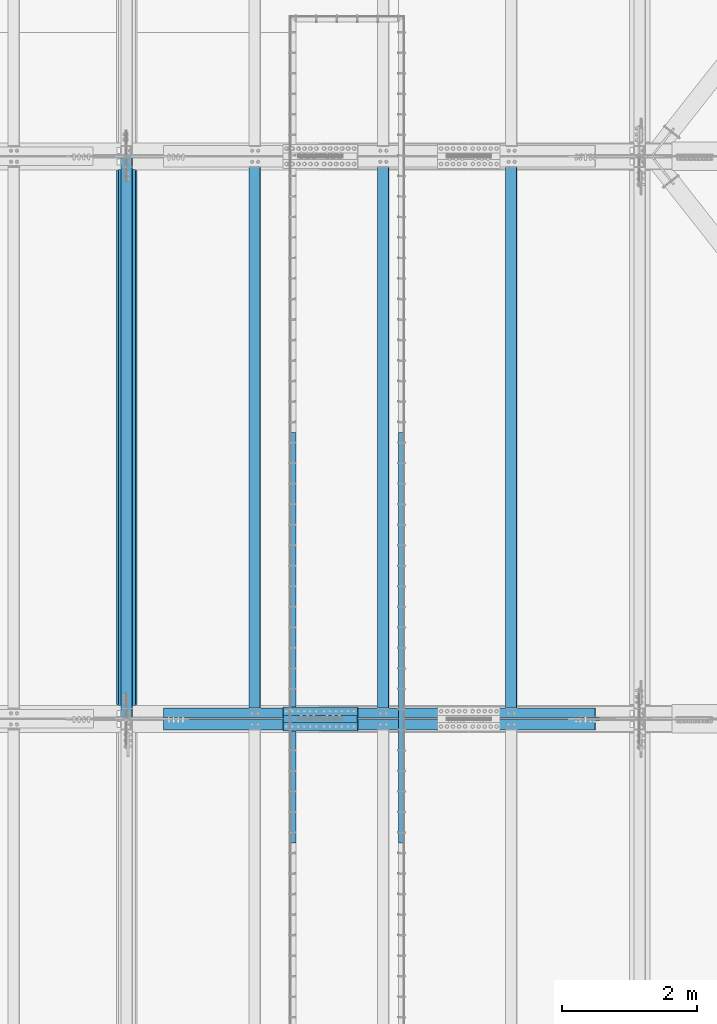
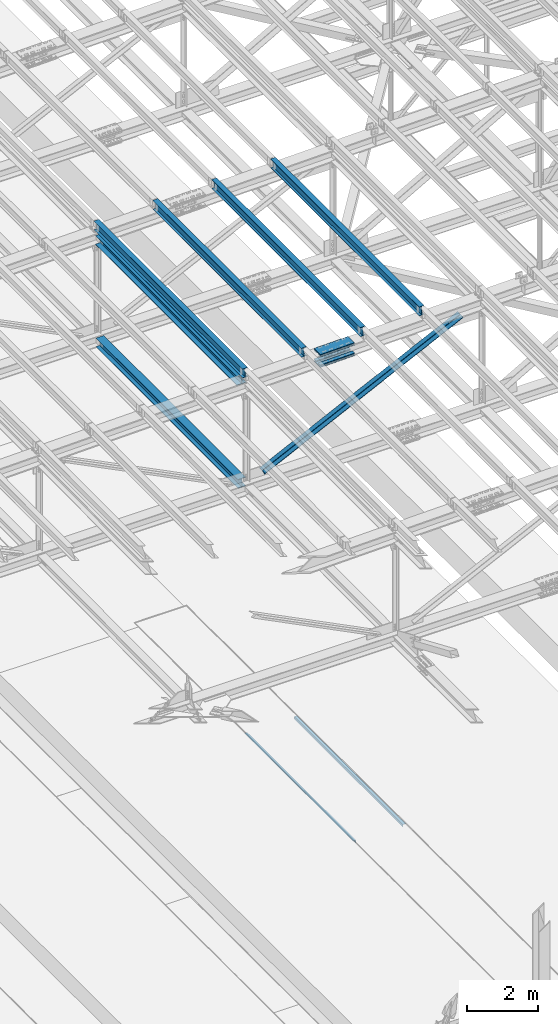
# One storey, part 1838 of 3843: 14 beams, 2 members, 11 elements without a shape of their own.
"""IFC2X3 building model written with IfcOpenShell, lengths in millimetres."""

from ifc_helpers import new_model, si_unit, frame, origin_with_axes, place, context, subcontext, project, spatial, faceted_brep, material, type_object, element, aggregate, save


model = new_model("IFC2X3")

# Units and contexts
model_context = context("Model", 3, precision=1e-05, world=origin_with_axes())
body_context = subcontext(model_context, "Body", "Model", "MODEL_VIEW")
ifc_project = project(units=[si_unit("LENGTHUNIT", "METRE", prefix="MILLI"), si_unit("AREAUNIT", "SQUARE_METRE"), si_unit("VOLUMEUNIT", "CUBIC_METRE"), si_unit("MASSUNIT", "GRAM", prefix="KILO"), si_unit("TIMEUNIT", "SECOND"), si_unit("PLANEANGLEUNIT", "RADIAN"), si_unit("SOLIDANGLEUNIT", "STERADIAN"), si_unit("THERMODYNAMICTEMPERATUREUNIT", "DEGREE_CELSIUS"), si_unit("LUMINOUSINTENSITYUNIT", "LUMEN")], contexts=[model_context])

# Site, building, storey
site_placement = place(None, origin_with_axes())
site = spatial("IfcSite", under=ifc_project, at=site_placement, CompositionType="ELEMENT")
building_placement = place(site_placement, origin_with_axes())
building = spatial("IfcBuilding", under=site, at=building_placement, Name="Undefined", CompositionType="ELEMENT")
storey_placement = place(building_placement, origin_with_axes())
storey = spatial("IfcBuildingStorey", under=building, at=storey_placement, Name="Undefined", CompositionType="ELEMENT", Elevation=0.0)

# Assembly, beam
assembly_1_placement = place(storey_placement, origin_with_axes())
assembly_1 = element("IfcElementAssembly", 1, at=assembly_1_placement, inside=storey, Name="EMBED_ANGLE", AssemblyPlace="NOTDEFINED", PredefinedType="RIGID_FRAME")
ifc_material_1 = material(Name="STEEL/A36")
beam_type_1 = type_object("IfcBeamType", Name="L3-1/2X3-1/2X5/16", PredefinedType="NOTDEFINED")
beam_1_placement = place(assembly_1_placement, frame((66713.862, 46456.6001953125, 30410.15), z_axis=(0.0, 0.0, -1.0), x_axis=(0.0, -1.0, 0.0)))
beam_1 = element("IfcBeam", 2, at=beam_1_placement, type_object=beam_type_1, material=ifc_material_1, Name="EMBED_ANGLE", ObjectType="L3-1/2X3-1/2X5/16", context=body_context, shape_type="Brep", body=[
    faceted_brep([(-3.63797880709171e-12, 44.4499999999971, -44.4500000000007), (-3.63797880709171e-12, 44.4499999999971, 44.4500000000007), (6096.0, 44.4499999999971, 44.4500000000007), (6096.0, 44.4499999999971, -44.4500000000007), (-3.63797880709171e-12, 36.5124999999971, 44.4500000000007), (6096.0, 36.5124999999971, 44.4500000000007), (-3.63797880709171e-12, 36.5124999999971, -36.5125000000007), (6096.0, 36.5124999999971, -36.5125000000007), (3.63797880709171e-12, -44.4499999999971, -36.5125000000007), (6096.0, -44.4499999999971, -36.5125000000007), (3.63797880709171e-12, -44.4499999999971, -44.4500000000007), (6096.0, -44.4499999999971, -44.4500000000007)], [[[0, 1, 2, 3]], [[1, 4, 5, 2]], [[4, 6, 7, 5]], [[6, 8, 9, 7]], [[8, 10, 11, 9]], [[10, 0, 3, 11]], [[5, 7, 9, 11, 3, 2]], [[10, 8, 6, 4, 1, 0]]]),
])
aggregate(assembly_1, [beam_1])

assembly_2_placement = place(storey_placement, origin_with_axes())
assembly_2 = element("IfcElementAssembly", 3, at=assembly_2_placement, inside=storey, Name="EMBED_ANGLE", AssemblyPlace="NOTDEFINED", PredefinedType="RIGID_FRAME")
beam_2_placement = place(assembly_2_placement, frame((65101.0255556641, 40360.6001953125, 30410.15), z_axis=(0.0, 0.0, -1.0), x_axis=(0.0, 1.0, 0.0)))
beam_2 = element("IfcBeam", 4, at=beam_2_placement, type_object=beam_type_1, material=ifc_material_1, Name="EMBED_ANGLE", ObjectType="L3-1/2X3-1/2X5/16", context=body_context, shape_type="Brep", body=[
    faceted_brep([(-3.63797880709171e-12, 44.4499999999971, -44.4500000000007), (-3.63797880709171e-12, 44.4499999999971, 44.4500000000007), (6096.0, 44.4499999999971, 44.4500000000007), (6096.0, 44.4499999999971, -44.4500000000007), (-3.63797880709171e-12, 36.5124999999971, 44.4500000000007), (6096.0, 36.5124999999971, 44.4500000000007), (-3.63797880709171e-12, 36.5124999999971, -36.5125000000007), (6096.0, 36.5124999999971, -36.5125000000007), (3.63797880709171e-12, -44.4499999999971, -36.5125000000007), (6096.0, -44.4499999999971, -36.5125000000007), (3.63797880709171e-12, -44.4499999999971, -44.4500000000007), (6096.0, -44.4499999999971, -44.4500000000007)], [[[0, 1, 2, 3]], [[1, 4, 5, 2]], [[4, 6, 7, 5]], [[6, 8, 9, 7]], [[8, 10, 11, 9]], [[10, 0, 3, 11]], [[5, 7, 9, 11, 3, 2]], [[10, 8, 6, 4, 1, 0]]]),
])
aggregate(assembly_2, [beam_2])

assembly_3_placement = place(storey_placement, origin_with_axes())
assembly_3 = element("IfcElementAssembly", 5, at=assembly_3_placement, inside=storey, Name="BEAM", AssemblyPlace="NOTDEFINED", PredefinedType="RIGID_FRAME")
ifc_material_2 = material(Name="STEEL/A992")
beam_type_2 = type_object("IfcBeamType", Name="W12X26", PredefinedType="NOTDEFINED")
beam_3_placement = place(assembly_3_placement, frame((62633.1092624511, 42201.8081954528, 46204.1114369362), z_axis=(-0.0211520982314614, -0.0018756519998351, 0.999774509912101), x_axis=(0.0, 0.999998240175376, 0.00187607200032924)))
beam_3 = element("IfcBeam", 6, at=beam_3_placement, type_object=beam_type_2, material=ifc_material_2, Name="BEAM", ObjectType="W12X26", context=body_context, shape_type="Brep", body=[
    faceted_brep([(12.6967464703193, 82.5499999994136, -155.575000000383), (12.7146120895923, 82.5499999994499, -146.050000000381), (8343.9292736213, 82.5499999999156, -146.050000022449), (8343.91140800202, 82.5499999998792, -155.575000022458), (12.7177619218128, 3.17499999958818, -146.050000000141), (8343.93242345352, 3.17500000005384, -146.050000022209), (13.2656409129268, 3.17500000040309, 146.050000000061), (8344.48030244464, 3.17500000086875, 146.049999977993), (13.2624910807062, 82.5500000002503, 146.049999999821), (8344.47715261242, 82.550000000716, 146.049999977753), (13.2803566999792, 82.5500000002867, 155.57499999983), (8344.49501823169, 82.5500000007523, 155.574999977762), (13.2869083509941, -82.5499999994208, 155.575000000332), (8344.50156988271, -82.5499999989552, 155.574999978257), (13.2690427317211, -82.5499999994499, 146.050000000323), (8344.48370426342, -82.549999998977, 146.049999978248), (13.2658928995006, -3.17499999958818, 146.050000000083), (8344.48055443121, -3.17499999912252, 146.049999978015), (12.7180139083866, -3.17500000041036, -146.050000000119), (8343.93267544009, -3.17499999993743, -146.050000022195), (12.7211637406144, -82.5500000002576, -146.049999999879), (8343.93582527231, -82.5499999997919, -146.050000021962), (12.7032981213342, -82.5500000002867, -155.574999999888), (8343.91795965304, -82.549999999821, -155.575000021956)], [[[0, 1, 2, 3]], [[1, 4, 5, 2]], [[4, 6, 7, 5]], [[6, 8, 9, 7]], [[8, 10, 11, 9]], [[10, 12, 13, 11]], [[12, 14, 15, 13]], [[14, 16, 17, 15]], [[16, 18, 19, 17]], [[18, 20, 21, 19]], [[20, 22, 23, 21]], [[22, 0, 3, 23]], [[5, 7, 9, 11, 13, 15, 17, 19, 21, 23, 3, 2]], [[22, 20, 18, 16, 14, 12, 10, 8, 6, 4, 1, 0]]]),
])
aggregate(assembly_3, [beam_3])

assembly_4_placement = place(storey_placement, origin_with_axes())
assembly_4 = element("IfcElementAssembly", 7, at=assembly_4_placement, inside=storey, Name="BEAM", AssemblyPlace="NOTDEFINED", PredefinedType="RIGID_FRAME")
beam_4_placement = place(assembly_4_placement, frame((68348.1092622879, 42201.7802351292, 46326.8579257853), z_axis=(-0.0211520977063192, -0.00205537399917375, 0.999774156597552), x_axis=(0.0, 0.99999788677105, 0.00205583399952916)))
beam_4 = element("IfcBeam", 8, at=beam_4_placement, type_object=beam_type_2, material=ifc_material_2, Name="BEAM", ObjectType="W12X26", context=body_context, shape_type="Brep", body=[
    faceted_brep([(12.6964371812865, 82.5500000000757, -155.574999999575), (12.7160146604147, 82.5500000000757, -146.049999999603), (8343.93362042758, 82.5500000005995, -146.050000024283), (8343.91404294845, 82.550000000585, -155.57500002427), (12.719466305447, 3.17499999966822, -146.049999999756), (8343.93707207261, 3.17500000017753, -146.050000024443), (13.3198423321519, 3.17500000039581, 146.049999999675), (8344.53744809931, 3.17500000090513, 146.049999974981), (13.3163906871123, 82.5500000008033, 146.049999999828), (8344.53399645427, 82.5500000013271, 146.049999975134), (13.3359681662478, 82.5500000008324, 155.574999999801), (8344.55357393341, 82.5500000013562, 155.574999975121), (13.3431475879115, -82.5500000000466, 155.574999999488), (8344.56075335508, -82.5499999995372, 155.574999974793), (13.3235701087833, -82.5500000000611, 146.049999999508), (8344.54117587594, -82.5499999995518, 146.049999974814), (13.320118463751, -3.17499999963911, 146.049999999661), (8344.5377242309, -3.1749999991298, 146.049999974966), (12.7197424370461, -3.17500000036671, -146.04999999977), (8343.93734820421, -3.17499999984284, -146.05000002445), (12.7231940820857, -82.5500000007742, -146.049999999916), (8343.94079984925, -82.5500000002648, -146.05000002461), (12.7036166029502, -82.5500000008033, -155.57499999991), (8343.92122237012, -82.5500000002794, -155.575000024597)], [[[0, 1, 2, 3]], [[1, 4, 5, 2]], [[4, 6, 7, 5]], [[6, 8, 9, 7]], [[8, 10, 11, 9]], [[10, 12, 13, 11]], [[12, 14, 15, 13]], [[14, 16, 17, 15]], [[16, 18, 19, 17]], [[18, 20, 21, 19]], [[20, 22, 23, 21]], [[22, 0, 3, 23]], [[5, 7, 9, 11, 13, 15, 17, 19, 21, 23, 3, 2]], [[22, 20, 18, 16, 14, 12, 10, 8, 6, 4, 1, 0]]]),
])
aggregate(assembly_4, [beam_4])

assembly_5_placement = place(storey_placement, origin_with_axes())
assembly_5 = element("IfcElementAssembly", 9, at=assembly_5_placement, inside=storey, Name="BEAM", AssemblyPlace="NOTDEFINED", PredefinedType="RIGID_FRAME")
beam_5_placement = place(assembly_5_placement, frame((66443.1092622962, 42201.788179392, 46286.529738134), z_axis=(-0.0211520975136227, -0.00200431100054993, 0.999774260274882), x_axis=(0.0, 0.999997990468655, 0.00200475900093949)))
beam_5 = element("IfcBeam", 10, at=beam_5_placement, type_object=beam_type_2, material=ifc_material_2, Name="BEAM", ObjectType="W12X26", context=body_context, shape_type="Brep", body=[
    faceted_brep([(12.6965249984351, 82.5500000000175, -155.575000000048), (12.7156160940722, 82.5500000000466, -146.050000000054), (8343.93235792132, 82.5500000001048, -146.050000003233), (8343.91326682567, 82.5500000000902, -155.575000003228), (12.7189819867563, 3.17499999959546, -146.049999999879), (8343.93572381399, 3.17499999966822, -146.050000003059), (13.3044422530875, 3.17500000039581, 146.049999999843), (8344.52118408032, 3.17500000046857, 146.049999996671), (13.3010763604034, 82.5500000008615, 146.049999999668), (8344.51781818763, 82.5500000009197, 146.049999996481), (13.3201674560478, 82.550000000876, 155.574999999662), (8344.53690928328, 82.5500000009342, 155.574999996483), (13.3271685128275, -82.5500000000466, 155.575000000026), (8344.54391034006, -82.5499999999884, 155.574999996854), (13.3080774171831, -82.5500000000757, 146.050000000039), (8344.52481924441, -82.5500000000029, 146.04999999686), (13.3047115245063, -3.17499999962456, 146.049999999857), (8344.52145335174, -3.17499999956635, 146.049999996678), (12.7192512581751, -3.17500000042492, -146.049999999865), (8343.93599308541, -3.17500000036671, -146.050000003052), (12.7226171508519, -82.5500000008906, -146.04999999969), (8343.9393589781, -82.5500000008178, -146.050000002862), (12.7035260552148, -82.5500000009051, -155.574999999677), (8343.92026788245, -82.5500000008469, -155.575000002857)], [[[0, 1, 2, 3]], [[1, 4, 5, 2]], [[4, 6, 7, 5]], [[6, 8, 9, 7]], [[8, 10, 11, 9]], [[10, 12, 13, 11]], [[12, 14, 15, 13]], [[14, 16, 17, 15]], [[16, 18, 19, 17]], [[18, 20, 21, 19]], [[20, 22, 23, 21]], [[22, 0, 3, 23]], [[5, 7, 9, 11, 13, 15, 17, 19, 21, 23, 3, 2]], [[22, 20, 18, 16, 14, 12, 10, 8, 6, 4, 1, 0]]]),
])
aggregate(assembly_5, [beam_5])

assembly_6_placement = place(storey_placement, origin_with_axes())
assembly_6 = element("IfcElementAssembly", 11, at=assembly_6_placement, inside=storey, Name="BEAM", AssemblyPlace="NOTDEFINED", PredefinedType="RIGID_FRAME")
beam_6_placement = place(assembly_6_placement, frame((64538.1092622937, 42201.7974398097, 46245.6404963415), z_axis=(-0.0211520980268542, -0.00194478699965839, 0.999774377823611), x_axis=(0.0, 0.999998108053895, 0.00194522200010466)))
beam_6 = element("IfcBeam", 12, at=beam_6_placement, type_object=beam_type_2, material=ifc_material_2, Name="BEAM", ObjectType="W12X26", context=body_context, shape_type="Brep", body=[
    faceted_brep([(12.6966274431325, 82.5500000002285, -155.574999999473), (12.7151515723817, 82.5500000002066, -146.049999999494), (8343.93091379489, 82.5500000001703, -146.049999997391), (8343.91238966565, 82.5500000001921, -155.574999997363), (12.718417504766, 3.17500000035943, -146.049999999625), (8343.93422907904, 3.17500000100699, -146.050000003583), (13.2864908016709, 3.17499999963911, 146.049999999639), (8344.50225302418, 3.17499999959546, 146.050000001742), (13.2832248692866, 82.549999999479, 146.049999999763), (8344.49898709179, 82.5499999994427, 146.050000001873), (13.3017489985359, 82.5499999994718, 155.574999999742), (8344.51751122103, 82.5499999994281, 155.575000001845), (13.3085421378928, -82.5500000002285, 155.574999999473), (8344.52430436039, -82.5500000002576, 155.575000001583), (13.2900180086435, -82.5500000001994, 146.049999999501), (8344.50578023115, -82.5500000002285, 146.050000001604), (13.2867520762666, -3.17500000035216, 146.049999999625), (8344.50251429876, -3.17500000038854, 146.050000001735), (12.7186787793617, -3.17499999962456, -146.049999999639), (8343.93444100186, -3.17499999966094, -146.049999997529), (12.7219447117386, -82.5499999994718, -146.049999999763), (8343.93770693424, -82.5499999995154, -146.049999997653), (12.7034205824966, -82.5499999994572, -155.574999999742), (8343.919182805, -82.5499999994863, -155.574999997632)], [[[0, 1, 2, 3]], [[1, 4, 5, 2]], [[4, 6, 7, 5]], [[6, 8, 9, 7]], [[8, 10, 11, 9]], [[10, 12, 13, 11]], [[12, 14, 15, 13]], [[14, 16, 17, 15]], [[16, 18, 19, 17]], [[18, 20, 21, 19]], [[20, 22, 23, 21]], [[22, 0, 3, 23]], [[5, 7, 9, 11, 13, 15, 17, 19, 21, 23, 3, 2]], [[22, 20, 18, 16, 14, 12, 10, 8, 6, 4, 1, 0]]]),
])
aggregate(assembly_6, [beam_6])

# Assembly, beams
assembly_7_placement = place(storey_placement, origin_with_axes())
assembly_7 = element("IfcElementAssembly", 13, at=assembly_7_placement, inside=storey, Name="BEAM", AssemblyPlace="NOTDEFINED", PredefinedType="RIGID_FRAME")
ifc_material_3 = material(Name="STEEL/A572-50")
beam_type_3 = type_object("IfcBeamType", PredefinedType="NOTDEFINED")
beam_7_placement = place(assembly_7_placement, frame((64955.3370624321, 42316.4, 46049.7907669812), z_axis=(0.0, -1.0, 0.0), x_axis=(0.999769188711818, 0.0, 0.0214841639938114)))
beam_7 = element("IfcBeam", 14, at=beam_7_placement, type_object=beam_type_3, material=ifc_material_3, Name="PLATE", context=body_context, shape_type="Brep", body=[
    faceted_brep([(-4.36557456851006e-11, 12.7000000000116, -63.5), (-4.36557456851006e-11, 12.7000000000116, 63.5), (1104.90000001677, 12.7000000017251, 63.5), (1104.90000001677, 12.7000000017251, -63.5), (1.45519152283669e-11, -12.700000000008, 63.5), (1104.90000001682, -12.6999999982909, 63.5), (1.45519152283669e-11, -12.700000000008, -63.5), (1104.90000001682, -12.6999999982909, -63.5)], [[[0, 1, 2, 3]], [[1, 4, 5, 2]], [[4, 6, 7, 5]], [[6, 0, 3, 7]], [[5, 7, 3, 2]], [[6, 4, 1, 0]]]),
])
beam_8_placement = place(assembly_7_placement, frame((64961.6801622345, 42316.4, 45754.6135495426), z_axis=(0.0, -1.0, 0.0), x_axis=(0.999769188711818, 0.0, 0.0214841639938114)))
beam_8 = element("IfcBeam", 15, at=beam_8_placement, type_object=beam_type_3, material=ifc_material_3, Name="PLATE", context=body_context, shape_type="Brep", body=[
    faceted_brep([(-4.36557456851006e-11, 12.7000000000116, -63.5), (-4.36557456851006e-11, 12.7000000000116, 63.5), (1104.90000001677, 12.7000000017251, 63.5), (1104.90000001677, 12.7000000017251, -63.5), (1.45519152283669e-11, -12.700000000008, 63.5), (1104.90000001682, -12.6999999982909, 63.5), (1.45519152283669e-11, -12.700000000008, -63.5), (1104.90000001682, -12.6999999982909, -63.5)], [[[0, 1, 2, 3]], [[1, 4, 5, 2]], [[4, 6, 7, 5]], [[6, 0, 3, 7]], [[5, 7, 3, 2]], [[6, 4, 1, 0]]]),
])
beam_9_placement = place(assembly_7_placement, frame((64955.3370624321, 42087.8, 46049.7907669812), z_axis=(0.0, -1.0, 0.0), x_axis=(0.999769188711818, 0.0, 0.0214841639938114)))
beam_9 = element("IfcBeam", 16, at=beam_9_placement, type_object=beam_type_3, material=ifc_material_3, Name="PLATE", context=body_context, shape_type="Brep", body=[
    faceted_brep([(-4.36557456851006e-11, 12.7000000000116, -63.5), (-4.36557456851006e-11, 12.7000000000116, 63.5), (1104.90000001677, 12.7000000017251, 63.5), (1104.90000001677, 12.7000000017251, -63.5), (1.45519152283669e-11, -12.700000000008, 63.5), (1104.90000001682, -12.6999999982909, 63.5), (1.45519152283669e-11, -12.700000000008, -63.5), (1104.90000001682, -12.6999999982909, -63.5)], [[[0, 1, 2, 3]], [[1, 4, 5, 2]], [[4, 6, 7, 5]], [[6, 0, 3, 7]], [[5, 7, 3, 2]], [[6, 4, 1, 0]]]),
])
beam_10_placement = place(assembly_7_placement, frame((64961.6801622345, 42087.8, 45754.6135495426), z_axis=(0.0, -1.0, 0.0), x_axis=(0.999769188711818, 0.0, 0.0214841639938114)))
beam_10 = element("IfcBeam", 17, at=beam_10_placement, type_object=beam_type_3, material=ifc_material_3, Name="PLATE", context=body_context, shape_type="Brep", body=[
    faceted_brep([(-4.36557456851006e-11, 12.7000000000116, -63.5), (-4.36557456851006e-11, 12.7000000000116, 63.5), (1104.90000001677, 12.7000000017251, 63.5), (1104.90000001677, 12.7000000017251, -63.5), (1.45519152283669e-11, -12.700000000008, 63.5), (1104.90000001682, -12.6999999982909, 63.5), (1.45519152283669e-11, -12.700000000008, -63.5), (1104.90000001682, -12.6999999982909, -63.5)], [[[0, 1, 2, 3]], [[1, 4, 5, 2]], [[4, 6, 7, 5]], [[6, 0, 3, 7]], [[5, 7, 3, 2]], [[6, 4, 1, 0]]]),
])
beam_type_4 = type_object("IfcBeamType", PredefinedType="NOTDEFINED")
beam_11_placement = place(assembly_7_placement, frame((66058.6498896111, 42202.1, 46135.5204175091), z_axis=(0.0, -1.0, 0.0), x_axis=(-0.999769188711818, 0.0, -0.0214841639938015)))
beam_11 = element("IfcBeam", 18, at=beam_11_placement, type_object=beam_type_4, material=ifc_material_3, Name="PLATE", context=body_context, shape_type="Brep", body=[
    faceted_brep([(-1.45519152283669e-11, 12.7000000000025, -177.800000000003), (-1.45519152283669e-11, 12.7000000000025, 177.800000000003), (1104.90000001682, 12.7000000017051, 177.800000000003), (1104.90000001682, 12.7000000017051, -177.800000000003), (4.36557456851006e-11, -12.7000000000171, 177.800000000003), (1104.90000001686, -12.6999999983072, 177.800000000003), (4.36557456851006e-11, -12.7000000000171, -177.800000000003), (1104.90000001686, -12.6999999983072, -177.800000000003)], [[[0, 1, 2, 3]], [[1, 4, 5, 2]], [[4, 6, 7, 5]], [[6, 0, 3, 7]], [[5, 7, 3, 2]], [[6, 4, 1, 0]]]),
])
beam_12_placement = place(assembly_7_placement, frame((66067.6616332914, 42202.1, 45716.4236846046), z_axis=(0.0, -1.0, 0.0), x_axis=(-0.999769188711818, 0.0, -0.0214841639938015)))
beam_12 = element("IfcBeam", 19, at=beam_12_placement, type_object=beam_type_4, material=ifc_material_3, Name="PLATE", context=body_context, shape_type="Brep", body=[
    faceted_brep([(-1.45519152283669e-11, 12.7000000000025, -177.800000000003), (-1.45519152283669e-11, 12.7000000000025, 177.800000000003), (1104.90000001682, 12.7000000017051, 177.800000000003), (1104.90000001682, 12.7000000017051, -177.800000000003), (4.36557456851006e-11, -12.7000000000171, 177.800000000003), (1104.90000001686, -12.6999999983072, 177.800000000003), (4.36557456851006e-11, -12.7000000000171, -177.800000000003), (1104.90000001686, -12.6999999983072, -177.800000000003)], [[[0, 1, 2, 3]], [[1, 4, 5, 2]], [[4, 6, 7, 5]], [[6, 0, 3, 7]], [[5, 7, 3, 2]], [[6, 4, 1, 0]]]),
])
aggregate(assembly_7, [beam_7, beam_8, beam_9, beam_10, beam_11, beam_12])

# Assembly, member
assembly_8_placement = place(storey_placement, origin_with_axes())
assembly_8 = element("IfcElementAssembly", 20, at=assembly_8_placement, inside=storey, Name="ANGLE", AssemblyPlace="NOTDEFINED", PredefinedType="RIGID_FRAME")
member_type = type_object("IfcMemberType", Name="L6X6X1/2", PredefinedType="NOTDEFINED")
member_1_placement = place(assembly_8_placement, frame((70256.4000000248, 42287.825, 46014.1417238708), z_axis=(0.0, 1.0, 0.0), x_axis=(-0.900081929817012, 0.0, -0.435720689911421)))
member_1 = element("IfcMember", 21, at=member_1_placement, type_object=member_type, material=ifc_material_3, Name="ANGLE", ObjectType="L6X6X1/2", context=body_context, shape_type="Brep", body=[
    faceted_brep([(701.375806744007, 76.199999999857, -76.1999999999971), (701.375806744007, 76.199999999857, 76.1999999999971), (7828.04613248694, 76.1999999977361, 76.1999999999971), (7828.04613248694, 76.1999999977361, -76.1999999999971), (701.375806743963, 63.4999999998381, 76.1999999999971), (7828.0461324869, 63.4999999977281, 76.1999999999971), (701.375806743963, 63.4999999998381, -63.5), (7828.0461324869, 63.4999999977281, -63.5), (701.375806743526, -76.2000000002681, -63.5), (7828.04613248646, -76.2000000023854, -63.5), (701.375806743526, -76.2000000002681, -76.1999999999971), (7828.04613248646, -76.2000000023854, -76.1999999999971)], [[[0, 1, 2, 3]], [[1, 4, 5, 2]], [[4, 6, 7, 5]], [[6, 8, 9, 7]], [[8, 10, 11, 9]], [[10, 0, 3, 11]], [[5, 7, 9, 11, 3, 2]], [[10, 8, 6, 4, 1, 0]]]),
])
aggregate(assembly_8, [member_1])

assembly_9_placement = place(storey_placement, origin_with_axes())
assembly_9 = element("IfcElementAssembly", 22, at=assembly_9_placement, inside=storey, Name="ANGLE", AssemblyPlace="NOTDEFINED", PredefinedType="RIGID_FRAME")
member_2_placement = place(assembly_9_placement, frame((62636.3999989338, 42116.375, 42325.3756847648), z_axis=(0.0, -1.0, 0.0), x_axis=(0.900081929817013, 0.0, 0.435720689911418)))
member_2 = element("IfcMember", 23, at=member_2_placement, type_object=member_type, material=ifc_material_3, Name="ANGLE", ObjectType="L6X6X1/2", context=body_context, shape_type="Brep", body=[
    faceted_brep([(637.849857298032, 76.2000000022708, -76.1999999999971), (637.849857298032, 76.2000000022708, 76.1999999999971), (7764.52018294758, 76.2000000269836, 76.1999999999971), (7764.52018294758, 76.2000000269836, -76.1999999999971), (637.849857298017, 63.5000000022628, 76.1999999999971), (7764.52018294758, 63.5000000269683, 76.1999999999971), (637.849857298017, 63.5000000022628, -63.5), (7764.52018294758, 63.5000000269683, -63.5), (637.849857298032, -76.1999999978543, -63.5), (7764.52018294758, -76.1999999731306, -63.5), (637.849857298032, -76.1999999978543, -76.1999999999971), (7764.52018294758, -76.1999999731306, -76.1999999999971)], [[[0, 1, 2, 3]], [[1, 4, 5, 2]], [[4, 6, 7, 5]], [[6, 8, 9, 7]], [[8, 10, 11, 9]], [[10, 0, 3, 11]], [[5, 7, 9, 11, 3, 2]], [[10, 8, 6, 4, 1, 0]]]),
])
aggregate(assembly_9, [member_2])

# Assembly, beam
assembly_10_placement = place(storey_placement, origin_with_axes())
assembly_10 = element("IfcElementAssembly", 24, at=assembly_10_placement, inside=storey, Name="BEAM", AssemblyPlace="NOTDEFINED", PredefinedType="RIGID_FRAME")
beam_type_5 = type_object("IfcBeamType", Name="W12X65", PredefinedType="NOTDEFINED")
beam_13_placement = place(assembly_10_placement, frame((62636.4, 42202.1000000001, 45851.6722387738), z_axis=(0.0, -0.00187607200032654, 0.999998240175376), x_axis=(0.0, 0.999998240175376, 0.00187607200032924)))
beam_13 = element("IfcBeam", 25, at=beam_13_placement, type_object=beam_type_5, material=ifc_material_2, Name="BEAM", ObjectType="W12X65", context=body_context, shape_type="Brep", body=[
    faceted_brep([(212.43648221514, 152.400000000001, -153.987500001072), (212.466264910552, 152.400000000001, -138.112500001014), (8143.63022242054, 152.400000000001, -138.112500022035), (8143.60043972512, 152.400000000001, -153.987500022085), (212.466264910552, 4.76249999999709, -138.112500001014), (8143.63022242054, 4.76249999999709, -138.112500022035), (212.984483810818, 4.76249999999709, 138.112499999894), (8144.14844132081, 4.76249999999709, 138.112499978881), (212.984483810818, 152.400000000001, 138.112499999894), (8144.14844132081, 152.400000000001, 138.112499978881), (213.014266506238, 152.400000000001, 153.987499999945), (8144.17822401623, 152.400000000001, 153.987499978932), (213.014266506238, -152.400000000001, 153.987499999945), (8144.17822401623, -152.400000000001, 153.987499978932), (212.984483810818, -152.400000000001, 138.112499999894), (8144.14844132081, -152.400000000001, 138.112499978881), (212.984483810818, -4.76249999999709, 138.112499999894), (8144.14844132081, -4.76249999999709, 138.112499978881), (212.466264910552, -4.76249999999709, -138.112500001014), (8143.63022242054, -4.76249999999709, -138.112500022035), (212.466264910552, -152.400000000001, -138.112500001014), (8143.63022242054, -152.400000000001, -138.112500022035), (212.43648221514, -152.400000000001, -153.987500001072), (8143.60043972512, -152.400000000001, -153.987500022085)], [[[0, 1, 2, 3]], [[1, 4, 5, 2]], [[4, 6, 7, 5]], [[6, 8, 9, 7]], [[8, 10, 11, 9]], [[10, 12, 13, 11]], [[12, 14, 15, 13]], [[14, 16, 17, 15]], [[16, 18, 19, 17]], [[18, 20, 21, 19]], [[20, 22, 23, 21]], [[22, 0, 3, 23]], [[5, 7, 9, 11, 13, 15, 17, 19, 21, 23, 3, 2]], [[22, 20, 18, 16, 14, 12, 10, 8, 6, 4, 1, 0]]]),
])
aggregate(assembly_10, [beam_13])

assembly_11_placement = place(storey_placement, origin_with_axes())
assembly_11 = element("IfcElementAssembly", 26, at=assembly_11_placement, inside=storey, Name="BEAM", AssemblyPlace="NOTDEFINED", PredefinedType="RIGID_FRAME")
beam_type_6 = type_object("IfcBeamType", Name="W12X53", PredefinedType="NOTDEFINED")
beam_14_placement = place(assembly_11_placement, frame((62636.4, 42202.1, 42325.330346676), z_axis=(0.0, -0.00187289000026067, 0.999998246139985), x_axis=(0.0, 0.999998246139985, 0.00187289000026184)))
beam_14 = element("IfcBeam", 27, at=beam_14_placement, type_object=beam_type_6, material=ifc_material_2, Name="BEAM", ObjectType="W12X53", context=body_context, shape_type="Brep", body=[
    faceted_brep([(198.15241909468, 127.0, -152.399999999077), (198.179178057493, 127.0, -138.112499999115), (8157.91813828902, 127.0, -138.112499976152), (8157.89137932621, 127.0, -152.399999976114), (198.179178057493, 4.76249999999709, -138.112499999115), (8157.91813828902, 4.76249999999709, -138.112499976152), (198.696518005156, 4.76249999999709, 138.112500000258), (8158.43547823669, 4.76249999999709, 138.11250002322), (198.696518005156, 127.0, 138.112500000258), (8158.43547823669, 127.0, 138.11250002322), (198.723276967969, 127.0, 152.400000000227), (8158.46223719949, 127.0, 152.40000002319), (198.723276967969, -127.0, 152.400000000227), (8158.46223719949, -127.0, 152.40000002319), (198.696518005156, -127.0, 138.112500000258), (8158.43547823669, -127.0, 138.11250002322), (198.696518005156, -4.76249999999709, 138.112500000258), (8158.43547823669, -4.76249999999709, 138.11250002322), (198.179178057493, -4.76249999999709, -138.112499999115), (8157.91813828902, -4.76249999999709, -138.112499976152), (198.179178057493, -127.0, -138.112499999115), (8157.91813828902, -127.0, -138.112499976152), (198.15241909468, -127.0, -152.399999999077), (8157.89137932621, -127.0, -152.399999976114)], [[[0, 1, 2, 3]], [[1, 4, 5, 2]], [[4, 6, 7, 5]], [[6, 8, 9, 7]], [[8, 10, 11, 9]], [[10, 12, 13, 11]], [[12, 14, 15, 13]], [[14, 16, 17, 15]], [[16, 18, 19, 17]], [[18, 20, 21, 19]], [[20, 22, 23, 21]], [[22, 0, 3, 23]], [[5, 7, 9, 11, 13, 15, 17, 19, 21, 23, 3, 2]], [[22, 20, 18, 16, 14, 12, 10, 8, 6, 4, 1, 0]]]),
])
aggregate(assembly_11, [beam_14])

save(model, "model.ifc")
